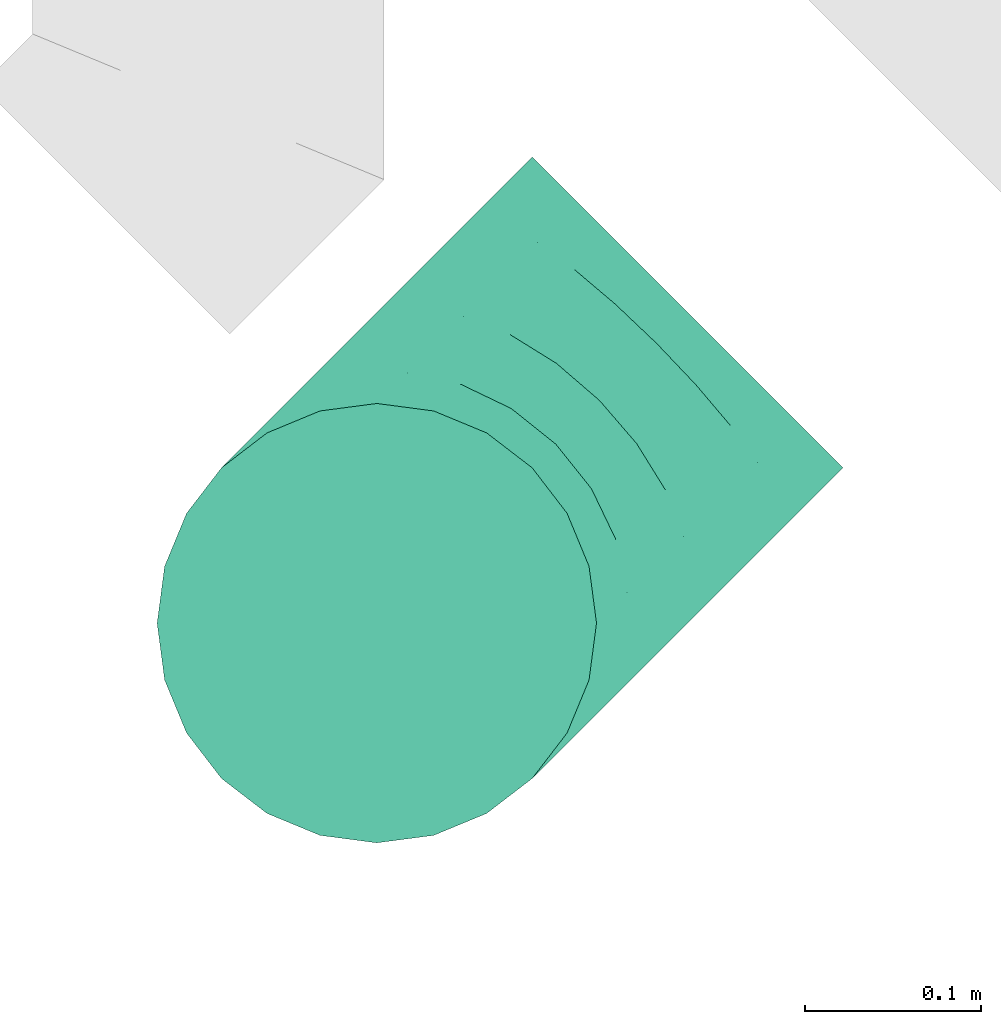
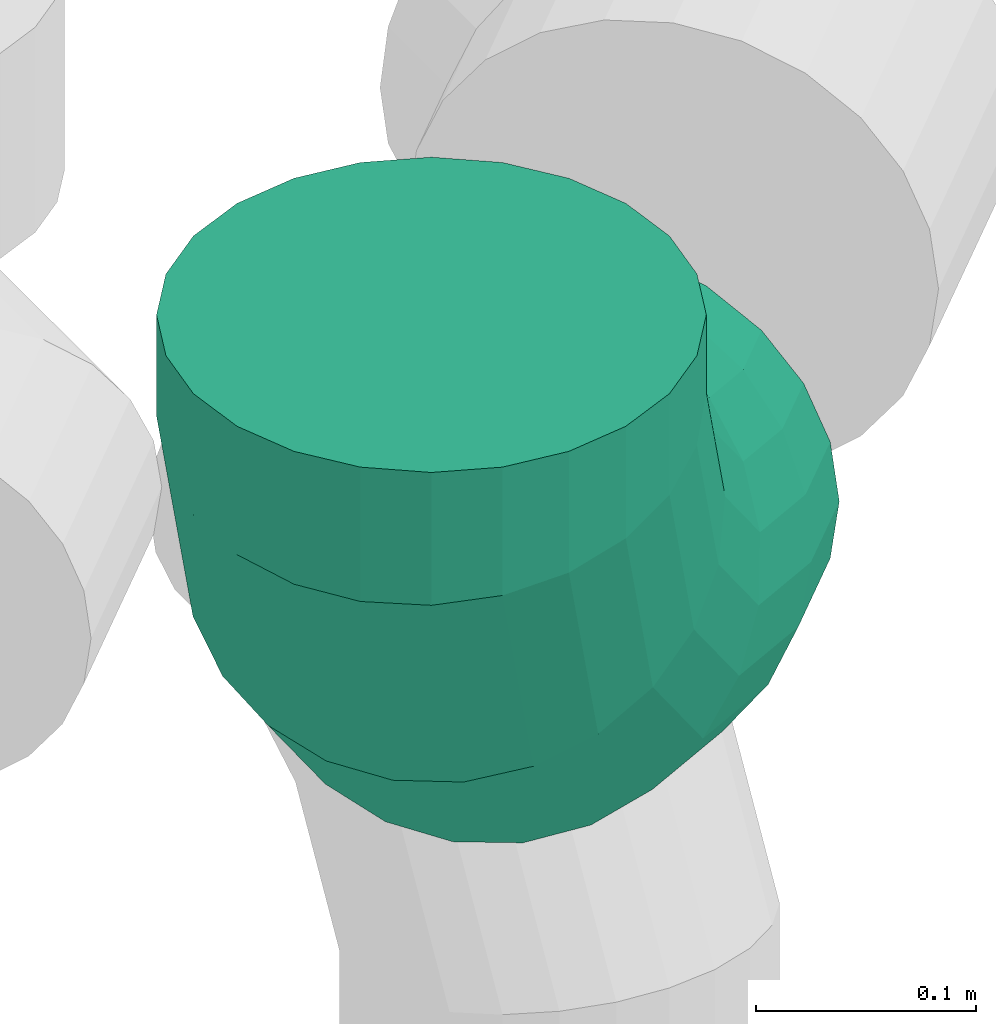
# One storey, part 57 of 59: 1 flow fitting.
"""IFC2X3 building model written with IfcOpenShell, lengths in millimetres."""

from ifc_helpers import new_model, entity, si_unit, converted_unit, derived_unit, direction, frame, origin, place, context, subcontext, project, spatial, faceted_brep, source, transform, mapped, material, type_object, type_shapes, element, save


model = new_model("IFC2X3")

# Units and contexts
model_context = context("Model", 3, precision=0.01, world=origin(), true_north=direction((6.12303176911189e-17, 1.0)))
body_context = subcontext(model_context, "Body", "Model", "MODEL_VIEW")
ifc_project = project(units=[si_unit("LENGTHUNIT", "METRE", prefix="MILLI"), si_unit("AREAUNIT", "SQUARE_METRE"), si_unit("VOLUMEUNIT", "CUBIC_METRE"), converted_unit("PLANEANGLEUNIT", "DEGREE", entity("IfcRatioMeasure", 0.0174532925199433), si_unit("PLANEANGLEUNIT", "RADIAN"), dimensions=[0, 0, 0, 0, 0, 0, 0]), si_unit("MASSUNIT", "GRAM", prefix="KILO"), derived_unit("MASSDENSITYUNIT", [(si_unit("MASSUNIT", "GRAM", prefix="KILO"), 1), (si_unit("LENGTHUNIT", "METRE"), -3)]), derived_unit("MOMENTOFINERTIAUNIT", [(si_unit("LENGTHUNIT", "METRE"), 4)]), si_unit("TIMEUNIT", "SECOND"), si_unit("FREQUENCYUNIT", "HERTZ"), si_unit("THERMODYNAMICTEMPERATUREUNIT", "DEGREE_CELSIUS"), derived_unit("THERMALTRANSMITTANCEUNIT", [(si_unit("MASSUNIT", "GRAM", prefix="KILO"), 1), (si_unit("THERMODYNAMICTEMPERATUREUNIT", "KELVIN"), -1), (si_unit("TIMEUNIT", "SECOND"), -3)]), derived_unit("VOLUMETRICFLOWRATEUNIT", [(si_unit("LENGTHUNIT", "METRE"), 3), (si_unit("TIMEUNIT", "SECOND"), -1)]), derived_unit("MASSFLOWRATEUNIT", [(si_unit("MASSUNIT", "GRAM", prefix="KILO"), 1), (si_unit("TIMEUNIT", "SECOND"), -1)]), derived_unit("ROTATIONALFREQUENCYUNIT", [(si_unit("TIMEUNIT", "SECOND"), -1)]), si_unit("ELECTRICCURRENTUNIT", "AMPERE"), si_unit("ELECTRICVOLTAGEUNIT", "VOLT"), si_unit("POWERUNIT", "WATT"), si_unit("FORCEUNIT", "NEWTON", prefix="KILO"), si_unit("ILLUMINANCEUNIT", "LUX"), si_unit("LUMINOUSFLUXUNIT", "LUMEN"), si_unit("LUMINOUSINTENSITYUNIT", "CANDELA"), derived_unit("USERDEFINED", [(si_unit("MASSUNIT", "GRAM", prefix="KILO"), -1), (si_unit("LENGTHUNIT", "METRE"), -2), (si_unit("TIMEUNIT", "SECOND"), 3), (si_unit("LUMINOUSFLUXUNIT", "LUMEN"), 1)]), derived_unit("LINEARVELOCITYUNIT", [(si_unit("LENGTHUNIT", "METRE"), 1), (si_unit("TIMEUNIT", "SECOND"), -1)]), si_unit("PRESSUREUNIT", "PASCAL"), derived_unit("USERDEFINED", [(si_unit("LENGTHUNIT", "METRE"), -2), (si_unit("MASSUNIT", "GRAM", prefix="KILO"), 1), (si_unit("TIMEUNIT", "SECOND"), -2)]), derived_unit("LINEARFORCEUNIT", [(si_unit("MASSUNIT", "GRAM", prefix="KILO"), 1), (si_unit("LENGTHUNIT", "METRE"), 1), (si_unit("TIMEUNIT", "SECOND"), -2), (si_unit("LENGTHUNIT", "METRE"), -1)]), derived_unit("PLANARFORCEUNIT", [(si_unit("MASSUNIT", "GRAM", prefix="KILO"), 1), (si_unit("LENGTHUNIT", "METRE"), 1), (si_unit("TIMEUNIT", "SECOND"), -2), (si_unit("LENGTHUNIT", "METRE"), -2)])], contexts=[model_context])

# Site, building, storey
site_placement = place(None, origin())
site = spatial("IfcSite", under=ifc_project, at=site_placement, CompositionType="ELEMENT")
building_placement = place(site_placement, origin())
building = spatial("IfcBuilding", under=site, at=building_placement, CompositionType="ELEMENT")
storey_placement = place(building_placement, frame((0.0, 0.0, 28200.0)))
storey = spatial("IfcBuildingStorey", under=building, at=storey_placement, CompositionType="ELEMENT", Elevation=28200.0)

# Flow fitting
ifc_material = material()
duct_fitting_type = type_object("IfcDuctFittingType", PredefinedType="NOTDEFINED", material=ifc_material)
shared_shape = source(origin(), body_context, "Body", "Brep", [
    faceted_brep([(-250.0, 0.0, -125.0), (-250.0, -32.35, -120.74), (-250.0, -62.5, -108.25), (-250.0, -88.39, -88.39), (-250.0, -108.25, -62.5), (-250.0, -120.74, -32.35), (-250.0, -125.0, 0.0), (-250.0, -120.74, 32.35), (-250.0, -108.25, 62.5), (-250.0, -88.39, 88.39), (-250.0, -62.5, 108.25), (-250.0, -32.35, 120.74), (-250.0, 0.0, 125.0), (-250.0, 32.35, 120.74), (-250.0, 62.5, 108.25), (-250.0, 88.39, 88.39), (-250.0, 108.25, 62.5), (-250.0, 120.74, 32.35), (-250.0, 125.0, 0.0), (-250.0, 120.74, -32.35), (-250.0, 108.25, -62.5), (-250.0, 88.39, -88.39), (-250.0, 62.5, -108.25), (-250.0, 32.35, -120.74), (-206.71, 32.35, 120.74), (-212.7, 62.5, 108.25), (-200.27, 0.0, 125.0), (-217.85, 88.39, 88.39), (-224.29, 120.74, 32.35), (-225.14, 125.0, 0.0), (-221.8, 108.25, 62.5), (-221.8, 108.25, -62.5), (-217.85, 88.39, -88.39), (-224.29, 120.74, -32.35), (-206.71, 32.35, -120.74), (-200.27, 0.0, -125.0), (-212.7, 62.5, -108.25), (-193.84, -32.35, -120.74), (-187.84, -62.5, -108.25), (-182.69, -88.39, -88.39), (-178.74, -108.25, -62.5), (-176.26, -120.74, -32.35), (-175.41, -125.0, 0.0), (-176.26, -120.74, 32.35), (-178.74, -108.25, 62.5), (-182.69, -88.39, 88.39), (-187.84, -62.5, 108.25), (-193.84, -32.35, 120.74), (-126.71, 65.49, 120.74), (-143.79, 91.05, 108.25), (-108.39, 38.06, 125.0), (-158.45, 112.99, 88.39), (-169.71, 129.83, 62.5), (-176.78, 140.42, 32.35), (-179.19, 144.03, 0.0), (-176.78, 140.42, -32.35), (-169.71, 129.83, -62.5), (-158.45, 112.99, -88.39), (-126.71, 65.49, -120.74), (-108.39, 38.06, -125.0), (-143.79, 91.05, -108.25), (-90.06, 10.63, -120.74), (-72.98, -14.92, -108.25), (-58.32, -36.87, -88.39), (-47.07, -53.71, -62.5), (-39.99, -64.3, -32.35), (-37.58, -67.91, 0.0), (-39.99, -64.3, 32.35), (-47.07, -53.71, 62.5), (-58.32, -36.87, 88.39), (-72.98, -14.92, 108.25), (-90.06, 10.63, 120.74), (-65.49, 126.71, 120.74), (-91.05, 143.79, 108.25), (-38.06, 108.39, 125.0), (-112.99, 158.45, 88.39), (-129.83, 169.71, 62.5), (-140.42, 176.78, 32.35), (-144.03, 179.19, 0.0), (-140.42, 176.78, -32.35), (-129.83, 169.71, -62.5), (-112.99, 158.45, -88.39), (-65.49, 126.71, -120.74), (-38.06, 108.39, -125.0), (-91.05, 143.79, -108.25), (-10.63, 90.06, -120.74), (14.92, 72.98, -108.25), (36.87, 58.32, -88.39), (53.71, 47.07, -62.5), (64.3, 39.99, -32.35), (67.91, 37.58, 0.0), (64.3, 39.99, 32.35), (53.71, 47.07, 62.5), (36.87, 58.32, 88.39), (14.92, 72.98, 108.25), (-10.63, 90.06, 120.74), (-32.35, 250.0, -120.74), (-62.5, 250.0, -108.25), (-88.39, 250.0, -88.39), (-108.25, 250.0, -62.5), (-120.74, 250.0, -32.35), (-125.0, 250.0, 0.0), (-120.74, 250.0, 32.35), (-108.25, 250.0, 62.5), (-88.39, 250.0, 88.39), (-62.5, 250.0, 108.25), (-32.35, 250.0, 120.74), (0.0, 250.0, 125.0), (32.35, 250.0, 120.74), (62.5, 250.0, 108.25), (88.39, 250.0, 88.39), (108.25, 250.0, 62.5), (120.74, 250.0, 32.35), (125.0, 250.0, 0.0), (120.74, 250.0, -32.35), (108.25, 250.0, -62.5), (88.39, 250.0, -88.39), (62.5, 250.0, -108.25), (32.35, 250.0, -120.74), (0.0, 250.0, -125.0), (-32.35, 206.71, 120.74), (-62.5, 212.7, 108.25), (0.0, 200.27, 125.0), (-88.39, 217.85, 88.39), (-108.25, 221.8, 62.5), (-120.74, 224.29, 32.35), (-125.0, 225.14, 0.0), (-120.74, 224.29, -32.35), (-108.25, 221.8, -62.5), (-88.39, 217.85, -88.39), (-32.35, 206.71, -120.74), (0.0, 200.27, -125.0), (-62.5, 212.7, -108.25), (32.35, 193.84, -120.74), (62.5, 187.84, -108.25), (88.39, 182.69, -88.39), (108.25, 178.74, -62.5), (120.74, 176.26, -32.35), (125.0, 175.41, 0.0), (120.74, 176.26, 32.35), (108.25, 178.74, 62.5), (88.39, 182.69, 88.39), (62.5, 187.84, 108.25), (32.35, 193.84, 120.74)], [[[0, 1, 2, 3, 4, 5, 6, 7, 8, 9, 10, 11, 12, 13, 14, 15, 16, 17, 18, 19, 20, 21, 22, 23]], [[24, 25, 14, 13]], [[26, 24, 13, 12]], [[14, 25, 27, 15]], [[28, 29, 18, 17]], [[30, 28, 17, 16]], [[15, 27, 30, 16]], [[20, 31, 32, 21]], [[33, 31, 20, 19]], [[18, 29, 33, 19]], [[34, 35, 0, 23]], [[36, 34, 23, 22]], [[32, 36, 22, 21]], [[1, 0, 35, 37]], [[2, 1, 37, 38]], [[3, 2, 38, 39]], [[5, 4, 40, 41]], [[6, 5, 41, 42]], [[39, 40, 4, 3]], [[6, 42, 43, 7]], [[7, 43, 44, 8]], [[45, 9, 8, 44]], [[9, 45, 46, 10]], [[10, 46, 47, 11]], [[26, 12, 11, 47]], [[48, 49, 25, 24]], [[50, 48, 24, 26]], [[27, 25, 49, 51]], [[52, 53, 28, 30]], [[51, 52, 30, 27]], [[29, 28, 53, 54]], [[55, 56, 31, 33]], [[54, 55, 33, 29]], [[32, 31, 56, 57]], [[58, 59, 35, 34]], [[60, 58, 34, 36]], [[57, 60, 36, 32]], [[37, 35, 59, 61]], [[38, 37, 61, 62]], [[39, 38, 62, 63]], [[41, 40, 64, 65]], [[42, 41, 65, 66]], [[63, 64, 40, 39]], [[43, 42, 66, 67]], [[44, 43, 67, 68]], [[68, 69, 45, 44]], [[46, 45, 69, 70]], [[47, 46, 70, 71]], [[26, 47, 71, 50]], [[72, 73, 49, 48]], [[74, 72, 48, 50]], [[51, 49, 73, 75]], [[76, 77, 53, 52]], [[75, 76, 52, 51]], [[54, 53, 77, 78]], [[79, 80, 56, 55]], [[78, 79, 55, 54]], [[57, 56, 80, 81]], [[82, 83, 59, 58]], [[84, 82, 58, 60]], [[81, 84, 60, 57]], [[61, 59, 83, 85]], [[62, 61, 85, 86]], [[63, 62, 86, 87]], [[65, 64, 88, 89]], [[66, 65, 89, 90]], [[87, 88, 64, 63]], [[67, 66, 90, 91]], [[68, 67, 91, 92]], [[92, 93, 69, 68]], [[70, 69, 93, 94]], [[71, 70, 94, 95]], [[50, 71, 95, 74]], [[96, 97, 98, 99, 100, 101, 102, 103, 104, 105, 106, 107, 108, 109, 110, 111, 112, 113, 114, 115, 116, 117, 118, 119]], [[120, 121, 73, 72]], [[122, 120, 72, 74]], [[75, 73, 121, 123]], [[124, 125, 77, 76]], [[123, 124, 76, 75]], [[78, 77, 125, 126]], [[127, 128, 80, 79]], [[126, 127, 79, 78]], [[81, 80, 128, 129]], [[130, 131, 83, 82]], [[132, 130, 82, 84]], [[129, 132, 84, 81]], [[85, 83, 131, 133]], [[86, 85, 133, 134]], [[87, 86, 134, 135]], [[89, 88, 136, 137]], [[90, 89, 137, 138]], [[135, 136, 88, 87]], [[91, 90, 138, 139]], [[92, 91, 139, 140]], [[140, 141, 93, 92]], [[94, 93, 141, 142]], [[95, 94, 142, 143]], [[74, 95, 143, 122]], [[120, 122, 107, 106]], [[121, 120, 106, 105]], [[123, 121, 105, 104]], [[125, 124, 103, 102]], [[126, 125, 102, 101]], [[123, 104, 103, 124]], [[126, 101, 100, 127]], [[127, 100, 99, 128]], [[128, 99, 98, 129]], [[132, 97, 96, 130]], [[130, 96, 119, 131]], [[132, 129, 98, 97]], [[131, 119, 118, 133]], [[133, 118, 117, 134]], [[116, 135, 134, 117]], [[136, 115, 114, 137]], [[137, 114, 113, 138]], [[115, 136, 135, 116]], [[112, 111, 140, 139]], [[113, 112, 139, 138]], [[111, 110, 141, 140]], [[143, 142, 109, 108]], [[122, 143, 108, 107]], [[110, 109, 142, 141]]]),
])
type_shapes(duct_fitting_type, [shared_shape])
flow_fitting_placement = place(storey_placement, frame((72718.49, 8800.75, 3000.0), z_axis=(-0.70710678118648, 0.707106781186615, 0.0), x_axis=(-0.70710678118661, -0.707106781186475, -1.24103817318969e-07)))
element("IfcFlowFitting", 1, at=flow_fitting_placement, inside=storey, type_object=duct_fitting_type, material=ifc_material, context=body_context, shape_type="MappedRepresentation", body=[
    mapped(shared_shape, transform((0.0, 0.0, 0.0), scale=1.0)),
])

save(model, "model.ifc")
